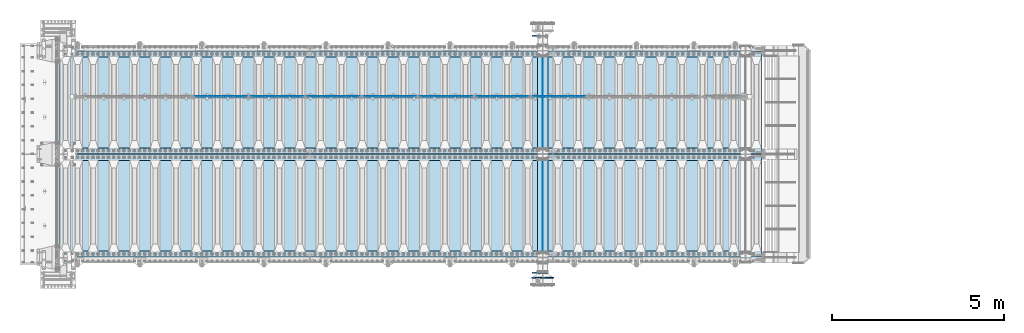
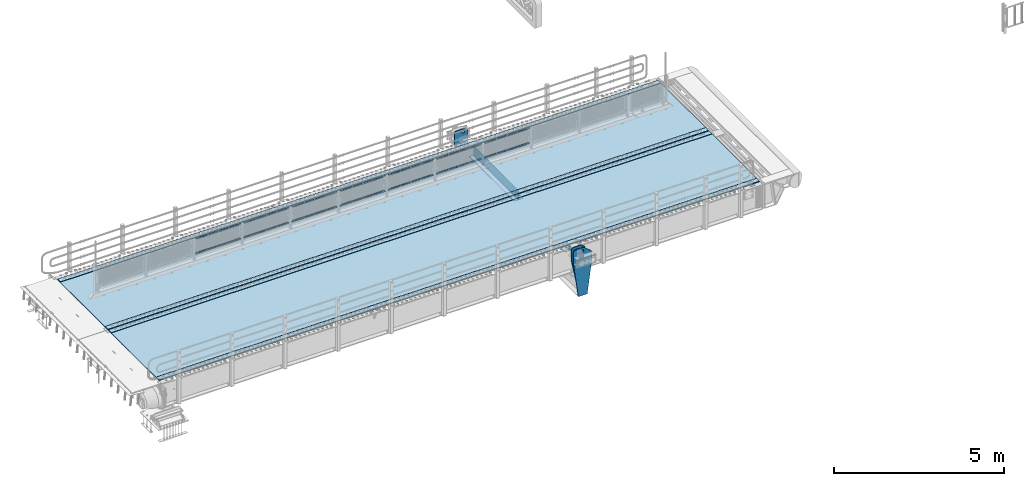
# One storey, part 193 of 242: 27 plates.
"""IFC2X3 building model written with IfcOpenShell, lengths in millimetres."""

from ifc_helpers import new_model, si_unit, frame, origin_with_axes, place, context, subcontext, project, spatial, faceted_brep, material, type_object, element, save


model = new_model("IFC2X3")

# Units and contexts
model_context = context("Model", 3, precision=1e-05, world=origin_with_axes())
body_context = subcontext(model_context, "Body", "Model", "MODEL_VIEW")
ifc_project = project(units=[si_unit("LENGTHUNIT", "METRE", prefix="MILLI"), si_unit("AREAUNIT", "SQUARE_METRE"), si_unit("VOLUMEUNIT", "CUBIC_METRE"), si_unit("MASSUNIT", "GRAM", prefix="KILO"), si_unit("TIMEUNIT", "SECOND"), si_unit("PLANEANGLEUNIT", "RADIAN"), si_unit("SOLIDANGLEUNIT", "STERADIAN"), si_unit("THERMODYNAMICTEMPERATUREUNIT", "DEGREE_CELSIUS"), si_unit("LUMINOUSINTENSITYUNIT", "LUMEN")], contexts=[model_context])

# Site, building, storey
site_placement = place(None, origin_with_axes())
site = spatial("IfcSite", under=ifc_project, at=site_placement, CompositionType="ELEMENT")
building_placement = place(site_placement, origin_with_axes())
building = spatial("IfcBuilding", under=site, at=building_placement, Name="Standard", CompositionType="ELEMENT")
storey_placement = place(building_placement, origin_with_axes())
storey = spatial("IfcBuildingStorey", under=building, at=storey_placement, Name="Undefined", CompositionType="ELEMENT", Elevation=0.0)

# Plates
ifc_material_1 = material(Name="STEEL/S355N")
plate_type_1 = type_object("IfcPlateType", PredefinedType="NOTDEFINED")
plate_1_placement = place(storey_placement, frame((-28255.0000000603, -17559.9999999654, -955.00001822199), z_axis=(-0.901283188008789, 0.0, 0.433230441004224), x_axis=(-0.433230441004227, 0.0, -0.901283188008787)))
element("IfcPlate", 1, at=plate_1_placement, inside=storey, type_object=plate_type_1, material=ifc_material_1, context=body_context, shape_type="Brep", body=[
    faceted_brep([(-929.368911797763, -15.0, 583.252555031781), (-929.368911797763, 15.0, 583.252555031781), (-937.308302015212, 15.0, 596.689503306556), (-937.308302015212, -15.0, 596.689503306556), (-939.501244651428, 15.0, 612.14189789633), (-939.501244651428, -15.0, 612.14189789633), (-935.613884069124, 15.0, 627.257251801122), (-935.613884069124, -15.0, 627.257251801122), (-926.238035677947, 15.0, 639.734389409939), (-926.238035677947, -15.0, 639.734389409939), (-912.801087403168, 15.0, 647.673779627392), (-912.801087403168, -15.0, 647.673779627392), (-897.348692813393, 15.0, 649.866722263607), (-897.348692813393, -15.0, 649.866722263607), (-882.233338908603, 15.0, 645.979361681304), (-882.233338908603, -15.0, 645.979361681304), (-869.756201299781, 15.0, 636.603513290123), (-869.756201299781, -15.0, 636.603513290123), (-861.816811082332, 15.0, 623.166565015348), (-861.816811082332, -15.0, 623.166565015348), (-859.623868446119, 15.0, 607.71417042557), (-859.623868446119, -15.0, 607.71417042557), (-863.511229028421, 15.0, 592.598816520782), (-863.511229028421, -15.0, 592.598816520782), (-872.8870774196, 15.0, 580.121678911961), (-872.8870774196, -15.0, 580.121678911961), (-886.324025694375, 15.0, 572.182288694512), (-886.324025694375, -15.0, 572.182288694512), (-901.77642028415, 15.0, 569.989346058297), (-901.77642028415, -15.0, 569.989346058297), (-916.89177418894, 15.0, 573.8767066406), (-916.89177418894, -15.0, 573.8767066406), (264.349946025895, -15.0, 42.1349881246242), (264.349946025895, 15.0, 42.1349881246242), (15.5957837766018, 14.9999999999964, 161.706590975653), (15.5957837766018, -15.0, 161.706590975653), (244.096420288086, -15.0, 1.45519152283669e-10), (244.096420288086, 15.0, 1.45519152283669e-10), (0.0, -15.0, 0.0), (0.0, 15.0, 0.0), (-976.801696777346, -15.0, 469.530822753906), (-976.801696777346, 15.0, 469.530822753906), (-1005.61097945758, -15.0, 584.572341407271), (-1005.61097945758, 15.0, 584.572341407271), (-1008.62086606961, -15.0, 603.379087420493), (-1008.62086606961, 15.0, 603.379087420493), (-1008.34154488137, -15.0, 622.423117789531), (-1008.34154488137, 15.0, 622.423117789531), (-1004.78138982928, -15.0, 641.133500175474), (-1004.78138982928, 15.0, 641.133500175474), (-998.047132923921, -15.0, 658.949304871177), (-998.047132923921, 15.0, 658.949304871177), (-903.392995239112, -15.0, 855.865677422375), (-903.392995239112, 15.0, 855.865677422375), (-891.965893301453, -15.0, 873.346258360991), (-891.965893301453, 15.0, 873.346258360991), (-876.403853384465, -15.0, 887.273651594027), (-876.403853384465, 15.0, 887.273651594027), (-857.767402657624, -15.0, 896.698728408119), (-857.767402657624, 15.0, 896.698728408119), (-837.326584280041, -15.0, 900.979185474844), (-837.326584280041, 15.0, 900.979185474844), (-816.474406068895, -15.0, 899.823316755585), (-816.474406068895, 15.0, 899.823316755585), (-796.631909330708, -15.0, 893.309892783487), (-796.631909330708, 15.0, 893.309892783487), (-427.105804443361, -15.0, 715.685424804688), (-427.105804443361, 15.0, 715.685424804688), (138.633743286131, -15.0, 288.410614013668), (138.633743286131, 15.0, 288.410614013668), (291.101928710938, -15.0, 97.7892227172888), (291.101928710938, 15.0, 97.7892227172888), (270.848403438671, -15.0, 55.6542355613092), (270.848403438671, 15.0, 55.6542355613092), (22.0942403916652, -15.0, 175.225838795785), (22.0942403916652, 14.9999999999964, 175.225838795785), (-855.850321889684, -15.0, 588.91635783331), (-852.143242431466, -15.0, 592.23404360508), (-847.175983301098, -15.0, 591.95870068884), (-843.85829752933, -15.0, 588.251621230622), (-844.133640445571, -15.0, 583.284362100254), (-847.840719903788, -15.0, 579.966676328488), (-852.807979034154, -15.0, 580.242019244724), (-856.125664805924, -15.0, 583.949098702946), (-844.133640445571, 15.0, 583.284362100254), (-847.840719903788, 15.0, 579.966676328488), (-843.85829752933, 15.0, 588.251621230622), (-847.175983301098, 15.0, 591.95870068884), (-852.143242431466, 15.0, 592.23404360508), (-855.850321889684, 15.0, 588.91635783331), (-856.125664805924, 15.0, 583.949098702946), (-852.807979034154, 15.0, 580.242019244724)], [[[0, 1, 2, 3]], [[3, 2, 4, 5]], [[5, 4, 6, 7]], [[7, 6, 8, 9]], [[9, 8, 10, 11]], [[11, 10, 12, 13]], [[13, 12, 14, 15]], [[15, 14, 16, 17]], [[17, 16, 18, 19]], [[19, 18, 20, 21]], [[21, 20, 22, 23]], [[23, 22, 24, 25]], [[25, 24, 26, 27]], [[27, 26, 28, 29]], [[29, 28, 30, 31]], [[31, 30, 1, 0]], [[32, 33, 34, 35]], [[36, 37, 33, 32]], [[36, 38, 39, 37]], [[38, 40, 41, 39]], [[40, 42, 43, 41]], [[42, 44, 45, 43]], [[44, 46, 47, 45]], [[46, 48, 49, 47]], [[48, 50, 51, 49]], [[50, 52, 53, 51]], [[52, 54, 55, 53]], [[54, 56, 57, 55]], [[56, 58, 59, 57]], [[58, 60, 61, 59]], [[60, 62, 63, 61]], [[62, 64, 65, 63]], [[64, 66, 67, 65]], [[66, 68, 69, 67]], [[68, 70, 71, 69]], [[71, 70, 72, 73]], [[74, 75, 73, 72]], [[35, 34, 75, 74]], [[72, 70, 68, 66, 64, 62, 60, 58, 56, 54, 52, 50, 48, 46, 44, 42, 40, 38, 36, 32, 35, 74], [3, 5, 7, 9, 11, 13, 15, 17, 19, 21, 23, 25, 27, 29, 31, 0], [76, 77, 78, 79, 80, 81, 82, 83]], [[80, 84, 85, 81]], [[79, 86, 84, 80]], [[78, 87, 86, 79]], [[77, 88, 87, 78]], [[76, 89, 88, 77]], [[83, 90, 89, 76]], [[82, 91, 90, 83]], [[81, 85, 91, 82]], [[37, 39, 41, 43, 45, 47, 49, 51, 53, 55, 57, 59, 61, 63, 65, 67, 69, 71, 73, 75, 34, 33], [26, 24, 22, 20, 18, 16, 14, 12, 10, 8, 6, 4, 2, 1, 30, 28], [84, 86, 87, 88, 89, 90, 91, 85]]]),
])
plate_2_placement = place(storey_placement, frame((-28254.9999999268, -24440.000000035, -955.000018229059), z_axis=(-0.901283188008789, 0.0, 0.433230441004224), x_axis=(-0.433230441004227, 0.0, -0.901283188008787)))
element("IfcPlate", 2, at=plate_2_placement, inside=storey, type_object=plate_type_1, material=ifc_material_1, context=body_context, shape_type="Brep", body=[
    faceted_brep([(22.0942403916652, -15.0, 175.225838795785), (22.0942403916652, 14.9999999999964, 175.225838795785), (270.848403438671, 15.0, 55.6542355613092), (270.848403438671, -15.0, 55.6542355613092), (15.5957837766018, -15.0, 161.706590975653), (15.5957837766018, 14.9999999999964, 161.706590975653), (264.349946025895, -15.0, 42.1349881246242), (264.349946025895, 15.0, 42.1349881246242), (244.096420288086, -15.0, 1.45519152283669e-10), (244.096420288086, 15.0, 1.45519152283669e-10), (0.0, -15.0, 0.0), (0.0, 15.0, 0.0), (-976.801818847653, -15.0000000000036, 469.530853271488), (-976.801818847653, 14.9999999999964, 469.530853271488), (-1005.61098604241, -15.0000000000036, 584.572481266798), (-1005.61098604241, 14.9999999999964, 584.572481266794), (-1008.62084772117, -15.0, 603.379189822339), (-1008.62084772117, 15.0, 603.379189822343), (-1008.341515547, -15.0, 622.423179098605), (-1008.341515547, 15.0, 622.423179098605), (-1004.78138982928, -15.0, 641.133500175474), (-1004.78138982928, 15.0, 641.133500175474), (-998.047132923921, -15.0, 658.949304871177), (-998.047132923921, 15.0, 658.949304871177), (-903.393050005918, -15.0, 855.865691431827), (-903.393050005916, 15.0, 855.865691431827), (-891.965949445444, -15.0000000000036, 873.346281101807), (-891.965949445446, 14.9999999999964, 873.346281101811), (-876.403907448015, -15.0000000000036, 887.273681839073), (-876.403907448015, 14.9999999999964, 887.273681839077), (-857.767451990489, -15.0000000000036, 896.6987638231), (-857.767451990489, 14.9999999999964, 896.698763823097), (-837.326627351593, -15.0, 900.979222969945), (-837.326627351591, 15.0, 900.979222969949), (-816.474442649631, -15.0, 899.82335291613), (-816.474442649631, 15.0, 899.82335291613), (-796.631940525467, -15.0, 893.309924335023), (-796.631940525465, 15.0, 893.309924335026), (-427.105804443354, -15.0, 715.685363769535), (-427.105804443354, 15.0, 715.685363769539), (138.633743286131, -15.0, 288.410614013668), (138.633743286131, 15.0, 288.410614013668), (291.101928710938, -15.0, 97.7892227172888), (291.101928710938, 15.0, 97.7892227172888), (-886.324025694375, -15.0, 572.182288694512), (-886.324025694375, 15.0, 572.182288694512), (-901.77642028415, 15.0, 569.989346058297), (-901.77642028415, -15.0, 569.989346058297), (-872.8870774196, -15.0, 580.121678911961), (-872.8870774196, 15.0, 580.121678911961), (-863.511229028421, -15.0, 592.598816520782), (-863.511229028421, 15.0, 592.598816520782), (-859.623868446119, -15.0, 607.71417042557), (-859.623868446119, 15.0, 607.71417042557), (-861.816811082332, -15.0, 623.166565015348), (-861.816811082332, 15.0, 623.166565015348), (-869.756201299781, -15.0, 636.603513290123), (-869.756201299781, 15.0, 636.603513290123), (-882.233338908603, -15.0, 645.979361681304), (-882.233338908603, 15.0, 645.979361681304), (-897.348692813393, -15.0, 649.866722263607), (-897.348692813393, 15.0, 649.866722263607), (-912.801087403168, -15.0, 647.673779627392), (-912.801087403168, 15.0, 647.673779627392), (-926.238035677947, -15.0, 639.734389409939), (-926.238035677947, 15.0, 639.734389409939), (-935.613884069124, -15.0, 627.257251801122), (-935.613884069124, 15.0, 627.257251801122), (-939.501244651428, -15.0, 612.14189789633), (-939.501244651428, 15.0, 612.14189789633), (-937.308302015212, -15.0, 596.689503306556), (-937.308302015212, 15.0, 596.689503306556), (-929.368911797763, -15.0, 583.252555031781), (-929.368911797763, 15.0, 583.252555031781), (-916.89177418894, -15.0, 573.8767066406), (-916.89177418894, 15.0, 573.8767066406), (-844.133640445571, 15.0, 583.284362100254), (-843.85829752933, 15.0, 588.251621230622), (-847.175983301098, 15.0, 591.95870068884), (-852.143242431466, 15.0, 592.23404360508), (-855.850321889684, 15.0, 588.91635783331), (-856.125664805924, 15.0, 583.949098702946), (-852.807979034154, 15.0, 580.242019244724), (-847.840719903788, 15.0, 579.966676328488), (-847.840719903788, -15.0, 579.966676328488), (-852.807979034154, -15.0, 580.242019244724), (-844.133640445571, -15.0, 583.284362100254), (-843.85829752933, -15.0, 588.251621230622), (-847.175983301098, -15.0, 591.95870068884), (-852.143242431466, -15.0, 592.23404360508), (-855.850321889684, -15.0, 588.91635783331), (-856.125664805924, -15.0, 583.949098702946)], [[[0, 1, 2, 3]], [[4, 5, 1, 0]], [[6, 7, 5, 4]], [[8, 9, 7, 6]], [[8, 10, 11, 9]], [[10, 12, 13, 11]], [[12, 14, 15, 13]], [[14, 16, 17, 15]], [[16, 18, 19, 17]], [[18, 20, 21, 19]], [[20, 22, 23, 21]], [[22, 24, 25, 23]], [[24, 26, 27, 25]], [[26, 28, 29, 27]], [[28, 30, 31, 29]], [[30, 32, 33, 31]], [[32, 34, 35, 33]], [[34, 36, 37, 35]], [[36, 38, 39, 37]], [[38, 40, 41, 39]], [[40, 42, 43, 41]], [[43, 42, 3, 2]], [[44, 45, 46, 47]], [[48, 49, 45, 44]], [[50, 51, 49, 48]], [[52, 53, 51, 50]], [[54, 55, 53, 52]], [[56, 57, 55, 54]], [[58, 59, 57, 56]], [[60, 61, 59, 58]], [[62, 63, 61, 60]], [[64, 65, 63, 62]], [[66, 67, 65, 64]], [[68, 69, 67, 66]], [[70, 71, 69, 68]], [[72, 73, 71, 70]], [[74, 75, 73, 72]], [[47, 46, 75, 74]], [[9, 11, 13, 15, 17, 19, 21, 23, 25, 27, 29, 31, 33, 35, 37, 39, 41, 43, 2, 1, 5, 7], [76, 77, 78, 79, 80, 81, 82, 83], [45, 49, 51, 53, 55, 57, 59, 61, 63, 65, 67, 69, 71, 73, 75, 46]], [[84, 83, 82, 85]], [[86, 76, 83, 84]], [[87, 77, 76, 86]], [[88, 78, 77, 87]], [[89, 79, 78, 88]], [[90, 80, 79, 89]], [[91, 81, 80, 90]], [[85, 82, 81, 91]], [[3, 42, 40, 38, 36, 34, 32, 30, 28, 26, 24, 22, 20, 18, 16, 14, 12, 10, 8, 6, 4, 0], [90, 89, 88, 87, 86, 84, 85, 91], [70, 68, 66, 64, 62, 60, 58, 56, 54, 52, 50, 48, 44, 47, 74, 72]]]),
])
ifc_material_2 = material(Name="Misc_Undefined")
plate_type_2 = type_object("IfcPlateType", PredefinedType="NOTDEFINED")
plate_3_placement = place(storey_placement, frame((-28711.4949882696, -19329.5, 351.520303374641), z_axis=(0.0, 0.0, 1.0), x_axis=(1.0, 0.0, 0.0)))
element("IfcPlate", 3, at=plate_3_placement, inside=storey, type_object=plate_type_2, material=ifc_material_2, context=body_context, shape_type="Brep", body=[
    faceted_brep([(0.0, -1.50000000000364, 0.0), (35.0002975463867, -1.5, 34.9996948242188), (35.0002975463867, 1.5, 34.9996948242188), (-3.63797880709171e-12, 1.49999999999636, 0.0), (1490.99035644531, -1.5, 34.9999923706055), (1490.99035644531, 1.5, 34.9999923706055), (1525.98999023438, -1.5, 2.81374923361e-11), (1525.98999023438, 1.5, 2.81374923361e-11)], [[[0, 1, 2, 3]], [[1, 4, 5, 2]], [[4, 6, 7, 5]], [[6, 0, 3, 7]], [[5, 7, 3, 2]], [[6, 4, 1, 0]]]),
])
plate_4_placement = place(storey_placement, frame((-27185.4999998124, -19329.5, 914.520000175701), z_axis=(-0.707103624179499, 0.0, 0.707109938179501), x_axis=(-0.707109938179495, 0.0, -0.707103624179505)))
element("IfcPlate", 4, at=plate_4_placement, inside=storey, type_object=plate_type_2, material=ifc_material_2, context=body_context, shape_type="Brep", body=[
    faceted_brep([(0.0, -1.50000000000364, 0.0), (1079.04980468751, -1.5, 1079.04028320313), (1079.04980468751, 1.5, 1079.04028320313), (-3.63797880709171e-12, 1.49999999999636, 0.0), (1079.04272460939, -1.5, 1029.53576660157), (1079.04272460939, 1.5, 1029.53576660157), (49.4976959228534, -1.5, -3.63797880709171e-12), (49.4976959228534, 1.5, -3.63797880709171e-12)], [[[0, 1, 2, 3]], [[1, 4, 5, 2]], [[4, 6, 7, 5]], [[6, 0, 3, 7]], [[5, 7, 3, 2]], [[6, 4, 1, 0]]]),
])
plate_5_placement = place(storey_placement, frame((-30344.4949882696, -19329.5, 351.520303374641), z_axis=(0.0, 0.0, 1.0), x_axis=(1.0, 0.0, 0.0)))
element("IfcPlate", 5, at=plate_5_placement, inside=storey, type_object=plate_type_2, material=ifc_material_2, context=body_context, shape_type="Brep", body=[
    faceted_brep([(0.0, -1.50000000000364, 0.0), (35.0002975463867, -1.5, 34.9996948242188), (35.0002975463867, 1.5, 34.9996948242188), (-3.63797880709171e-12, 1.49999999999636, 0.0), (1490.99035644531, -1.5, 34.9999923706055), (1490.99035644531, 1.5, 34.9999923706055), (1525.98999023438, -1.5, 2.81374923361e-11), (1525.98999023438, 1.5, 2.81374923361e-11)], [[[0, 1, 2, 3]], [[1, 4, 5, 2]], [[4, 6, 7, 5]], [[6, 0, 3, 7]], [[5, 7, 3, 2]], [[6, 4, 1, 0]]]),
])
plate_6_placement = place(storey_placement, frame((-28818.4999998124, -19329.5, 914.520000175701), z_axis=(-0.707103624179499, 0.0, 0.707109938179501), x_axis=(-0.707109938179495, 0.0, -0.707103624179505)))
element("IfcPlate", 6, at=plate_6_placement, inside=storey, type_object=plate_type_2, material=ifc_material_2, context=body_context, shape_type="Brep", body=[
    faceted_brep([(0.0, -1.50000000000364, 0.0), (1079.04980468751, -1.5, 1079.04028320313), (1079.04980468751, 1.5, 1079.04028320313), (-3.63797880709171e-12, 1.49999999999636, 0.0), (1079.04272460939, -1.5, 1029.53576660157), (1079.04272460939, 1.5, 1029.53576660157), (49.4976959228534, -1.5, -3.63797880709171e-12), (49.4976959228534, 1.5, -3.63797880709171e-12)], [[[0, 1, 2, 3]], [[1, 4, 5, 2]], [[4, 6, 7, 5]], [[6, 0, 3, 7]], [[5, 7, 3, 2]], [[6, 4, 1, 0]]]),
])
plate_7_placement = place(storey_placement, frame((-31977.4949882696, -19329.5, 351.520303374641), z_axis=(0.0, 0.0, 1.0), x_axis=(1.0, 0.0, 0.0)))
element("IfcPlate", 7, at=plate_7_placement, inside=storey, type_object=plate_type_2, material=ifc_material_2, context=body_context, shape_type="Brep", body=[
    faceted_brep([(0.0, -1.50000000000364, 0.0), (35.0002975463867, -1.5, 34.9996948242188), (35.0002975463867, 1.5, 34.9996948242188), (-3.63797880709171e-12, 1.49999999999636, 0.0), (1490.99035644531, -1.5, 34.9999923706055), (1490.99035644531, 1.5, 34.9999923706055), (1525.98999023438, -1.5, 2.81374923361e-11), (1525.98999023438, 1.5, 2.81374923361e-11)], [[[0, 1, 2, 3]], [[1, 4, 5, 2]], [[4, 6, 7, 5]], [[6, 0, 3, 7]], [[5, 7, 3, 2]], [[6, 4, 1, 0]]]),
])
plate_8_placement = place(storey_placement, frame((-30451.4999998124, -19329.5, 914.520000175701), z_axis=(-0.707103624179499, 0.0, 0.707109938179501), x_axis=(-0.707109938179495, 0.0, -0.707103624179505)))
element("IfcPlate", 8, at=plate_8_placement, inside=storey, type_object=plate_type_2, material=ifc_material_2, context=body_context, shape_type="Brep", body=[
    faceted_brep([(0.0, -1.50000000000364, 0.0), (1079.04980468751, -1.5, 1079.04028320313), (1079.04980468751, 1.5, 1079.04028320313), (-3.63797880709171e-12, 1.49999999999636, 0.0), (1079.04272460939, -1.5, 1029.53576660157), (1079.04272460939, 1.5, 1029.53576660157), (49.4976959228534, -1.5, -3.63797880709171e-12), (49.4976959228534, 1.5, -3.63797880709171e-12)], [[[0, 1, 2, 3]], [[1, 4, 5, 2]], [[4, 6, 7, 5]], [[6, 0, 3, 7]], [[5, 7, 3, 2]], [[6, 4, 1, 0]]]),
])
plate_9_placement = place(storey_placement, frame((-33610.4949882696, -19329.5, 351.520303374641), z_axis=(0.0, 0.0, 1.0), x_axis=(1.0, 0.0, 0.0)))
element("IfcPlate", 9, at=plate_9_placement, inside=storey, type_object=plate_type_2, material=ifc_material_2, context=body_context, shape_type="Brep", body=[
    faceted_brep([(0.0, -1.50000000000364, 0.0), (35.0002975463867, -1.5, 34.9996948242188), (35.0002975463867, 1.5, 34.9996948242188), (-3.63797880709171e-12, 1.49999999999636, 0.0), (1490.99035644531, -1.5, 34.9999923706055), (1490.99035644531, 1.5, 34.9999923706055), (1525.98999023438, -1.5, 2.81374923361e-11), (1525.98999023438, 1.5, 2.81374923361e-11)], [[[0, 1, 2, 3]], [[1, 4, 5, 2]], [[4, 6, 7, 5]], [[6, 0, 3, 7]], [[5, 7, 3, 2]], [[6, 4, 1, 0]]]),
])
plate_10_placement = place(storey_placement, frame((-32084.4999998124, -19329.5, 914.520000175701), z_axis=(-0.707103624179499, 0.0, 0.707109938179501), x_axis=(-0.707109938179495, 0.0, -0.707103624179505)))
element("IfcPlate", 10, at=plate_10_placement, inside=storey, type_object=plate_type_2, material=ifc_material_2, context=body_context, shape_type="Brep", body=[
    faceted_brep([(0.0, -1.50000000000364, 0.0), (1079.04980468751, -1.5, 1079.04028320313), (1079.04980468751, 1.5, 1079.04028320313), (-3.63797880709171e-12, 1.49999999999636, 0.0), (1079.04272460939, -1.5, 1029.53576660157), (1079.04272460939, 1.5, 1029.53576660157), (49.4976959228534, -1.5, -3.63797880709171e-12), (49.4976959228534, 1.5, -3.63797880709171e-12)], [[[0, 1, 2, 3]], [[1, 4, 5, 2]], [[4, 6, 7, 5]], [[6, 0, 3, 7]], [[5, 7, 3, 2]], [[6, 4, 1, 0]]]),
])
plate_11_placement = place(storey_placement, frame((-35243.4949882696, -19329.5, 351.520303374641), z_axis=(0.0, 0.0, 1.0), x_axis=(1.0, 0.0, 0.0)))
element("IfcPlate", 11, at=plate_11_placement, inside=storey, type_object=plate_type_2, material=ifc_material_2, context=body_context, shape_type="Brep", body=[
    faceted_brep([(0.0, -1.50000000000364, 0.0), (35.0002975463867, -1.5, 34.9996948242188), (35.0002975463867, 1.5, 34.9996948242188), (-3.63797880709171e-12, 1.49999999999636, 0.0), (1490.99035644531, -1.5, 34.9999923706055), (1490.99035644531, 1.5, 34.9999923706055), (1525.98999023438, -1.5, 2.81374923361e-11), (1525.98999023438, 1.5, 2.81374923361e-11)], [[[0, 1, 2, 3]], [[1, 4, 5, 2]], [[4, 6, 7, 5]], [[6, 0, 3, 7]], [[5, 7, 3, 2]], [[6, 4, 1, 0]]]),
])
plate_12_placement = place(storey_placement, frame((-33717.4999998124, -19329.5, 914.520000175701), z_axis=(-0.707103624179499, 0.0, 0.707109938179501), x_axis=(-0.707109938179495, 0.0, -0.707103624179505)))
element("IfcPlate", 12, at=plate_12_placement, inside=storey, type_object=plate_type_2, material=ifc_material_2, context=body_context, shape_type="Brep", body=[
    faceted_brep([(0.0, -1.50000000000364, 0.0), (1079.04980468751, -1.5, 1079.04028320313), (1079.04980468751, 1.5, 1079.04028320313), (-3.63797880709171e-12, 1.49999999999636, 0.0), (1079.04272460939, -1.5, 1029.53576660157), (1079.04272460939, 1.5, 1029.53576660157), (49.4976959228534, -1.5, -3.63797880709171e-12), (49.4976959228534, 1.5, -3.63797880709171e-12)], [[[0, 1, 2, 3]], [[1, 4, 5, 2]], [[4, 6, 7, 5]], [[6, 0, 3, 7]], [[5, 7, 3, 2]], [[6, 4, 1, 0]]]),
])
plate_13_placement = place(storey_placement, frame((-36876.4949882696, -19329.5, 351.520303374641), z_axis=(0.0, 0.0, 1.0), x_axis=(1.0, 0.0, 0.0)))
element("IfcPlate", 13, at=plate_13_placement, inside=storey, type_object=plate_type_2, material=ifc_material_2, context=body_context, shape_type="Brep", body=[
    faceted_brep([(0.0, -1.50000000000364, 0.0), (35.0002975463867, -1.5, 34.9996948242188), (35.0002975463867, 1.5, 34.9996948242188), (-3.63797880709171e-12, 1.49999999999636, 0.0), (1490.99035644531, -1.5, 34.9999923706055), (1490.99035644531, 1.5, 34.9999923706055), (1525.98999023438, -1.5, 2.81374923361e-11), (1525.98999023438, 1.5, 2.81374923361e-11)], [[[0, 1, 2, 3]], [[1, 4, 5, 2]], [[4, 6, 7, 5]], [[6, 0, 3, 7]], [[5, 7, 3, 2]], [[6, 4, 1, 0]]]),
])
plate_14_placement = place(storey_placement, frame((-35350.4999998124, -19329.5, 914.520000175701), z_axis=(-0.707103624179499, 0.0, 0.707109938179501), x_axis=(-0.707109938179495, 0.0, -0.707103624179505)))
element("IfcPlate", 14, at=plate_14_placement, inside=storey, type_object=plate_type_2, material=ifc_material_2, context=body_context, shape_type="Brep", body=[
    faceted_brep([(0.0, -1.50000000000364, 0.0), (1079.04980468751, -1.5, 1079.04028320313), (1079.04980468751, 1.5, 1079.04028320313), (-3.63797880709171e-12, 1.49999999999636, 0.0), (1079.04272460939, -1.5, 1029.53576660157), (1079.04272460939, 1.5, 1029.53576660157), (49.4976959228534, -1.5, -3.63797880709171e-12), (49.4976959228534, 1.5, -3.63797880709171e-12)], [[[0, 1, 2, 3]], [[1, 4, 5, 2]], [[4, 6, 7, 5]], [[6, 0, 3, 7]], [[5, 7, 3, 2]], [[6, 4, 1, 0]]]),
])
plate_15_placement = place(storey_placement, frame((-38509.4949882696, -19329.5, 351.520303374641), z_axis=(0.0, 0.0, 1.0), x_axis=(1.0, 0.0, 0.0)))
element("IfcPlate", 15, at=plate_15_placement, inside=storey, type_object=plate_type_2, material=ifc_material_2, context=body_context, shape_type="Brep", body=[
    faceted_brep([(0.0, -1.50000000000364, 0.0), (35.0002975463867, -1.5, 34.9996948242188), (35.0002975463867, 1.5, 34.9996948242188), (-3.63797880709171e-12, 1.49999999999636, 0.0), (1490.99035644531, -1.5, 34.9999923706055), (1490.99035644531, 1.5, 34.9999923706055), (1525.98999023438, -1.5, 2.81374923361e-11), (1525.98999023438, 1.5, 2.81374923361e-11)], [[[0, 1, 2, 3]], [[1, 4, 5, 2]], [[4, 6, 7, 5]], [[6, 0, 3, 7]], [[5, 7, 3, 2]], [[6, 4, 1, 0]]]),
])
plate_16_placement = place(storey_placement, frame((-36983.4999998124, -19329.5, 914.520000175701), z_axis=(-0.707103624179499, 0.0, 0.707109938179501), x_axis=(-0.707109938179495, 0.0, -0.707103624179505)))
element("IfcPlate", 16, at=plate_16_placement, inside=storey, type_object=plate_type_2, material=ifc_material_2, context=body_context, shape_type="Brep", body=[
    faceted_brep([(0.0, -1.50000000000364, 0.0), (1079.04980468751, -1.5, 1079.04028320313), (1079.04980468751, 1.5, 1079.04028320313), (-3.63797880709171e-12, 1.49999999999636, 0.0), (1079.04272460939, -1.5, 1029.53576660157), (1079.04272460939, 1.5, 1029.53576660157), (49.4976959228534, -1.5, -3.63797880709171e-12), (49.4976959228534, 1.5, -3.63797880709171e-12)], [[[0, 1, 2, 3]], [[1, 4, 5, 2]], [[4, 6, 7, 5]], [[6, 0, 3, 7]], [[5, 7, 3, 2]], [[6, 4, 1, 0]]]),
])
plate_type_3 = type_object("IfcPlateType", PredefinedType="NOTDEFINED")
plate_17_placement = place(storey_placement, frame((-28264.9999999403, -24580.000000035, -1480.00001822256), z_axis=(0.0, 0.0, 1.0), x_axis=(-1.0, 0.0, 0.0)))
element("IfcPlate", 17, at=plate_17_placement, inside=storey, type_object=plate_type_3, material=ifc_material_1, context=body_context, shape_type="Brep", body=[
    faceted_brep([(145.403805922699, -15.0000000000036, 1549.59619407771), (145.403805922699, 14.9999999999964, 1549.59619407771), (150.000000000411, 14.9999999999964, 1551.5), (150.000000000411, -15.0000000000036, 1551.5), (154.596194078124, 14.9999999999964, 1549.59619407771), (154.596194078124, -15.0000000000036, 1549.59619407771), (156.500000000411, 14.9999999999964, 1545.0), (156.500000000411, -15.0000000000036, 1545.0), (154.596194078124, 14.9999999999964, 1540.40380592229), (154.596194078124, -15.0000000000036, 1540.40380592229), (150.000000000411, 14.9999999999964, 1538.5), (150.000000000411, -15.0000000000036, 1538.5), (145.403805922699, 14.9999999999964, 1540.40380592229), (145.403805922699, -15.0000000000036, 1540.40380592229), (143.500000000411, 14.9999999999964, 1545.0), (143.500000000411, -15.0000000000036, 1545.0), (300.0, -15.0, 0.0), (0.0, -15.0, 0.0), (0.0, 15.0, 0.0), (300.0, 15.0, 0.0), (462.5, -15.0, 1210.0), (462.5, 15.0, 1210.0), (462.5, -15.0, 1630.0), (462.5, 15.0, 1630.0), (459.774066103124, -15.0, 1650.7055236082), (459.774066103124, 15.0, 1650.7055236082), (451.782032302755, -15.0, 1670.0), (451.782032302755, 15.0, 1670.0), (439.068542494922, -15.0, 1686.56854249492), (439.068542494922, 15.0, 1686.56854249492), (422.5, -15.0, 1699.28203230276), (422.5, 15.0, 1699.28203230276), (403.205523608201, -15.0, 1707.27406610313), (403.205523608201, 15.0, 1707.27406610313), (382.5, -15.0, 1710.0), (382.5, 15.0, 1710.0), (151.788081037081, -15.0, 1710.0), (151.788081037081, 15.0, 1710.0), (132.694887325029, -15.0, 1708.33028179541), (132.694887325029, 15.0, 1708.33028179541), (114.181334578883, -15.0, 1703.37181734316), (114.181334578883, 15.0, 1703.37181734316), (96.809466726856, -15.0, 1695.27513824985), (96.809466726856, 15.0, 1695.27513824985), (81.1066678416755, -15.0, 1684.28604765144), (81.1066678416755, 15.0, 1684.28604765144), (-162.5, -15.0, 1480.0), (-162.5, 15.0, 1480.0), (-162.5, -15.0, 1210.0), (-162.5, 15.0, 1210.0), (121.715728752948, -15.0, 1628.28427124746), (134.692662705809, -15.0, 1636.95518130045), (150.000000000411, -15.0, 1640.0), (165.307337295013, -15.0, 1636.95518130045), (178.284271247874, -15.0, 1628.28427124746), (186.955181300862, -15.0, 1615.3073372946), (190.000000000411, -15.0, 1600.0), (186.955181300862, -15.0, 1584.6926627054), (178.284271247874, -15.0, 1571.71572875254), (165.307337295013, -15.0, 1563.04481869955), (150.000000000411, -15.0, 1560.0), (134.692662705809, -15.0, 1563.04481869955), (121.715728752948, -15.0, 1571.71572875254), (113.04481869996, -15.0, 1584.6926627054), (110.000000000411, -15.0, 1600.0), (113.04481869996, -15.0, 1615.3073372946), (121.715728752948, 14.9999999999527, 1571.71572875254), (113.04481869996, 14.9999999999527, 1584.6926627054), (134.692662705809, 14.9999999999527, 1563.04481869955), (150.000000000411, 14.9999999999527, 1560.0), (165.307337295013, 14.9999999999527, 1563.04481869955), (178.284271247874, 14.9999999999527, 1571.71572875254), (186.955181300862, 14.9999999999527, 1584.6926627054), (190.000000000411, 14.9999999999527, 1600.0), (186.955181300862, 14.9999999999527, 1615.3073372946), (178.284271247874, 14.9999999999527, 1628.28427124746), (165.307337295013, 14.9999999999527, 1636.95518130045), (150.000000000411, 14.9999999999527, 1640.0), (134.692662705809, 14.9999999999527, 1636.95518130045), (121.715728752948, 14.9999999999527, 1628.28427124746), (113.04481869996, 14.9999999999527, 1615.3073372946), (110.000000000411, 14.9999999999527, 1600.0)], [[[0, 1, 2, 3]], [[3, 2, 4, 5]], [[5, 4, 6, 7]], [[7, 6, 8, 9]], [[9, 8, 10, 11]], [[11, 10, 12, 13]], [[13, 12, 14, 15]], [[15, 14, 1, 0]], [[16, 17, 18, 19]], [[20, 16, 19, 21]], [[22, 20, 21, 23]], [[24, 22, 23, 25]], [[26, 24, 25, 27]], [[28, 26, 27, 29]], [[30, 28, 29, 31]], [[32, 30, 31, 33]], [[34, 32, 33, 35]], [[36, 34, 35, 37]], [[38, 36, 37, 39]], [[40, 38, 39, 41]], [[42, 40, 41, 43]], [[44, 42, 43, 45]], [[46, 44, 45, 47]], [[48, 46, 47, 49]], [[17, 48, 49, 18]], [[16, 20, 22, 24, 26, 28, 30, 32, 34, 36, 38, 40, 42, 44, 46, 48, 17], [3, 5, 7, 9, 11, 13, 15, 0], [50, 51, 52, 53, 54, 55, 56, 57, 58, 59, 60, 61, 62, 63, 64, 65]], [[62, 66, 67, 63]], [[61, 68, 66, 62]], [[60, 69, 68, 61]], [[59, 70, 69, 60]], [[58, 71, 70, 59]], [[57, 72, 71, 58]], [[56, 73, 72, 57]], [[55, 74, 73, 56]], [[54, 75, 74, 55]], [[53, 76, 75, 54]], [[52, 77, 76, 53]], [[51, 78, 77, 52]], [[50, 79, 78, 51]], [[65, 80, 79, 50]], [[64, 81, 80, 65]], [[63, 67, 81, 64]], [[47, 45, 43, 41, 39, 37, 35, 33, 31, 29, 27, 25, 23, 21, 19, 18, 49], [10, 8, 6, 4, 2, 1, 14, 12], [66, 68, 69, 70, 71, 72, 73, 74, 75, 76, 77, 78, 79, 80, 81, 67]]]),
])
plate_type_4 = type_object("IfcPlateType", PredefinedType="NOTDEFINED")
for number, where, z_axis, x_axis in (
    (18, (-28415.0, -18175.0, 0.0), (0.0, 0.0, -1.0), (0.0, -1.0, 0.0)),
    (19, (-28415.0, -21175.0, 0.0), (0.0, 0.0, -1.0), (0.0, -1.0, 0.0)),
):
    element("IfcPlate", number, at=place(storey_placement, frame(where, z_axis=z_axis, x_axis=x_axis)), inside=storey, type_object=plate_type_4, material=ifc_material_1, context=body_context, shape_type="Brep", body=[
        faceted_brep([(0.0, -5.0, 0.0), (0.0, -5.0, 336.0), (0.0, 5.0, 336.0), (0.0, 5.0, 0.0), (2650.0, -5.0, 336.0), (2650.0, 5.0, 336.0), (2650.0, -5.0, 0.0), (2650.0, 5.0, 0.0)], [[[0, 1, 2, 3]], [[1, 4, 5, 2]], [[4, 6, 7, 5]], [[6, 0, 3, 7]], [[5, 7, 3, 2]], [[6, 4, 1, 0]]]),
    ])
plate_type_5 = type_object("IfcPlateType", PredefinedType="NOTDEFINED")
for number, where, z_axis, x_axis in (
    (20, (-28565.0, -20825.0, -343.0), (0.0, 1.0, 0.0), (1.0, 0.0, 0.0)),
    (21, (-28565.0, -23825.0, -343.0), (0.0, 1.0, 0.0), (1.0, 0.0, 0.0)),
):
    element("IfcPlate", number, at=place(storey_placement, frame(where, z_axis=z_axis, x_axis=x_axis)), inside=storey, type_object=plate_type_5, material=ifc_material_1, context=body_context, shape_type="Brep", body=[
        faceted_brep([(0.0, -7.0, 0.0), (0.0, -7.0, 2650.0), (0.0, 7.0, 2650.0), (0.0, 7.0, 0.0), (300.0, -7.0, 2650.0), (300.0, 7.0, 2650.0), (300.0, -7.0, 0.0), (300.0, 7.0, 0.0)], [[[0, 1, 2, 3]], [[1, 4, 5, 2]], [[4, 6, 7, 5]], [[6, 0, 3, 7]], [[5, 7, 3, 2]], [[6, 4, 1, 0]]]),
    ])
ifc_material_3 = material(Name="STEEL/S235JR")
plate_type_6 = type_object("IfcPlateType", PredefinedType="NOTDEFINED")
for number, where, z_axis, x_axis in (
    (22, (-22070.0, -20985.0, 20.0), (-1.0, 0.0, 0.0), (0.0, 1.0, 0.0)),
    (23, (-22070.0, -18185.0, 20.0), (-1.0, 0.0, 0.0), (0.0, 1.0, 0.0)),
    (24, (-22070.0, -23985.0, 20.0), (-1.0, 0.0, 0.0), (0.0, 1.0, 0.0)),
    (25, (-22070.0, -21185.0, 20.0), (-1.0, 0.0, 0.0), (0.0, 1.0, 0.0)),
):
    element("IfcPlate", number, at=place(storey_placement, frame(where, z_axis=z_axis, x_axis=x_axis)), inside=storey, type_object=plate_type_6, material=ifc_material_3, context=body_context, shape_type="Brep", body=[
        faceted_brep([(0.0, -6.0, 0.0), (0.0, -6.0, 20360.0), (0.0, 6.0, 20360.0), (0.0, 6.0, 0.0), (170.0, -6.0, 20360.0), (170.0, 6.0, 20360.0), (170.0, -6.0, 0.0), (170.0, 6.0, 0.0)], [[[0, 1, 2, 3]], [[1, 4, 5, 2]], [[4, 6, 7, 5]], [[6, 0, 3, 7]], [[5, 7, 3, 2]], [[6, 4, 1, 0]]]),
    ])
plate_type_7 = type_object("IfcPlateType", PredefinedType="NOTDEFINED")
for number, where, z_axis, x_axis in (
    (26, (-42440.0, -18005.0, 7.0), (1.0, 0.0, 0.0), (0.0, -1.0, 0.0)),
    (27, (-42440.0, -21005.0, 7.0), (1.0, 0.0, 0.0), (0.0, -1.0, 0.0)),
):
    element("IfcPlate", number, at=place(storey_placement, frame(where, z_axis=z_axis, x_axis=x_axis)), inside=storey, type_object=plate_type_7, material=ifc_material_1, context=body_context, shape_type="Brep", body=[
        faceted_brep([(0.0, -7.0, 0.0), (-2.96859070658684e-09, -7.0, 20380.0), (-2.96859070658684e-09, 7.0, 20380.0), (0.0, 7.0, 0.0), (2990.0, -7.0, 20380.0), (2990.0, 7.0, 20380.0), (2990.0, -7.0, 0.0), (2990.0, 7.0, 0.0)], [[[0, 1, 2, 3]], [[1, 4, 5, 2]], [[4, 6, 7, 5]], [[6, 0, 3, 7]], [[5, 7, 3, 2]], [[6, 4, 1, 0]]]),
    ])

save(model, "model.ifc")
